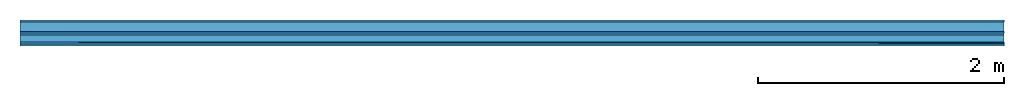
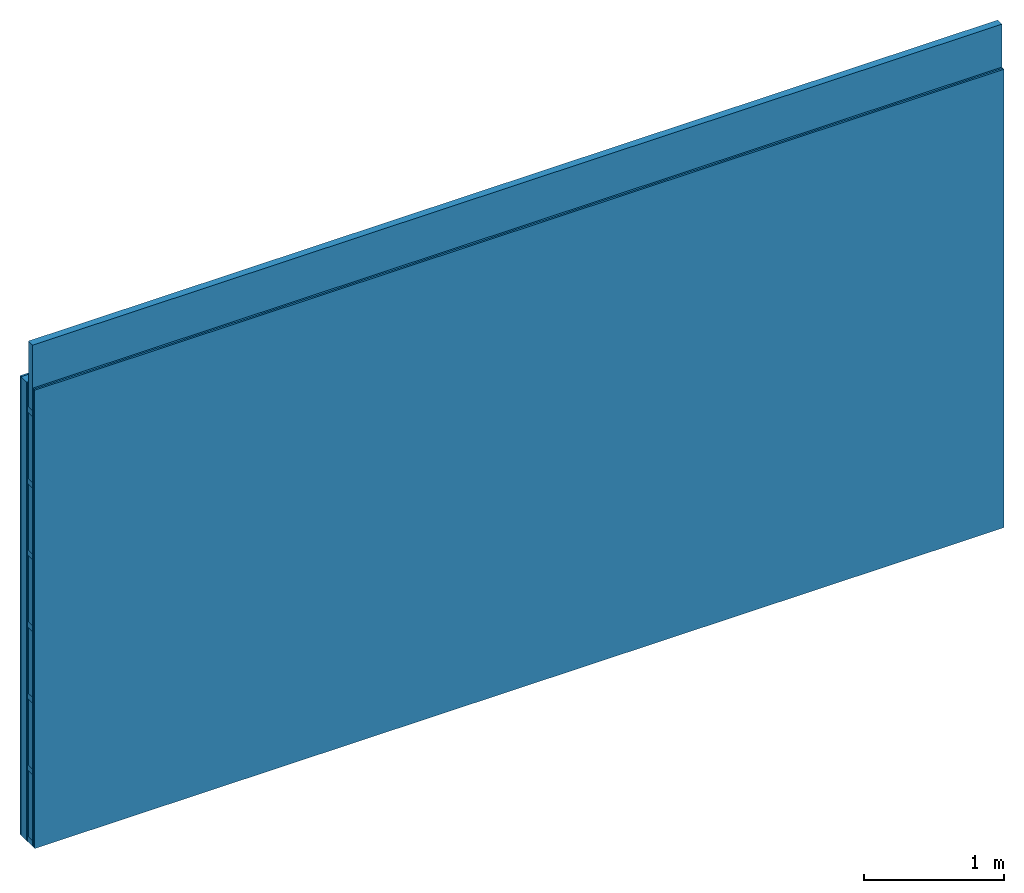
# One storey: 4 plates, 3 members, 1 element without a shape of its own.
"""IFC4 building model written with IfcOpenShell, lengths in metres."""

from ifc_helpers import new_model, si_unit, derived_unit, direction, frame, frame_2d, origin, origin_with_axes, place, context, project, spatial, rectangle, extrude, material, layer, layer_set, type_object, element, aggregate, save


model = new_model("IFC4")

# Units and contexts
plan_context = context("Plan", 3, precision=1e-05, world=origin(), true_north=direction((0.0, 1.0)))
model_context = context("Model", 3, precision=1e-05, world=origin(), true_north=direction((0.0, 1.0)))
ifc_project = project(units=[si_unit("LENGTHUNIT", "METRE"), derived_unit("SOUNDPRESSUREUNIT", [(si_unit("PRESSUREUNIT", "PASCAL", prefix="MICRO"), 0)]), si_unit("ENERGYUNIT", "JOULE", prefix="MEGA"), si_unit("MASSUNIT", "GRAM", prefix="KILO"), derived_unit("THERMALTRANSMITTANCEUNIT", [(si_unit("POWERUNIT", "WATT"), 1), (si_unit("AREAUNIT", "SQUARE_METRE"), -1), (si_unit("THERMODYNAMICTEMPERATUREUNIT", "KELVIN"), -1)]), derived_unit("AREADENSITYUNIT", [(si_unit("MASSUNIT", "GRAM", prefix="KILO"), 1), (si_unit("AREAUNIT", "SQUARE_METRE"), -1)]), derived_unit("USERDEFINED", [(si_unit("ENERGYUNIT", "JOULE", prefix="MEGA"), 1), (si_unit("AREAUNIT", "SQUARE_METRE"), -1)])], contexts=[plan_context, model_context])

# Site, building, storey
site = spatial("IfcSite", under=ifc_project)
building_placement = place(None, origin())
building = spatial("IfcBuilding", under=site, at=building_placement)
storey_placement = place(building_placement, origin())
storey = spatial("IfcBuildingStorey", under=building, at=storey_placement)

# Wall, members, plates
ifc_material_1 = material(Name="Glued joints")
ifc_layer_1 = layer(ifc_material_1, 0.0, Name="Surface")
ifc_material_2 = material(Category="03.007")
ifc_layer_2 = layer(ifc_material_2, 0.015, Name="1st layer")
ifc_material_3 = material(Name="of the art")
ifc_layer_3 = layer(ifc_material_3, 0.0, Name="Bond")
ifc_layer_4 = layer(None, 0.08, Name="Support")
ifc_material_4 = material(Name="Air")
ifc_layer_5 = layer(ifc_material_4, 0.01, Name="Coupling")
ifc_layer_6 = layer(None, 0.075, Name="Battens / profiles")
ifc_layer_7 = layer(ifc_material_2, 0.015, Name="Covering 1st layer")
ifc_layer_8 = layer(ifc_material_2, 0.015, Name="Covering 2nd layer")
ifc_layer_9 = layer(ifc_material_1, 0.0, Name="Surface")
ifc_layer_set = layer_set([ifc_layer_1, ifc_layer_2, ifc_layer_3, ifc_layer_4, ifc_layer_5, ifc_layer_6, ifc_layer_7, ifc_layer_8, ifc_layer_9])
wall_type = type_object("IfcWallType", Name="C0117", PredefinedType="NOTDEFINED", material=ifc_layer_set)
wall_placement = place(None, frame((0.0, 0.0, 0.0), z_axis=(0.0, -1.0, 0.0), x_axis=(1.0, 0.0, 0.0)))
wall = element("IfcWall", 1, at=wall_placement, inside=storey, type_object=wall_type, material=ifc_layer_set, Name="Wall #1")
ifc_material_5 = material()
member_1_placement = place(wall_placement, origin())
member_1 = element("IfcMember", 2, at=member_1_placement, material=ifc_material_5, Name="Support", context=plan_context, shape_type="SweptSolid", body=[
    extrude(rectangle(XDim=1.0, YDim=0.08, at=frame_2d((0.5, 0.04), x_axis=(1.0, 0.0))), frame((0.0, 4.0, 0.015), z_axis=(0.0, -1.0, 0.0), x_axis=(1.0, 0.0, 0.0)), (0.0, 0.0, 1.0), 4.0),
    extrude(rectangle(XDim=1.0, YDim=0.08, at=frame_2d((0.5, 0.04), x_axis=(1.0, 0.0))), frame((1.0, 4.0, 0.015), z_axis=(0.0, -1.0, 0.0), x_axis=(1.0, 0.0, 0.0)), (0.0, 0.0, 1.0), 4.0),
    extrude(rectangle(XDim=1.0, YDim=0.08, at=frame_2d((0.5, 0.04), x_axis=(1.0, 0.0))), frame((2.0, 4.0, 0.015), z_axis=(0.0, -1.0, 0.0), x_axis=(1.0, 0.0, 0.0)), (0.0, 0.0, 1.0), 4.0),
    extrude(rectangle(XDim=1.0, YDim=0.08, at=frame_2d((0.5, 0.04), x_axis=(1.0, 0.0))), frame((3.0, 4.0, 0.015), z_axis=(0.0, -1.0, 0.0), x_axis=(1.0, 0.0, 0.0)), (0.0, 0.0, 1.0), 4.0),
    extrude(rectangle(XDim=1.0, YDim=0.08, at=frame_2d((0.5, 0.04), x_axis=(1.0, 0.0))), frame((4.0, 4.0, 0.015), z_axis=(0.0, -1.0, 0.0), x_axis=(1.0, 0.0, 0.0)), (0.0, 0.0, 1.0), 4.0),
    extrude(rectangle(XDim=1.0, YDim=0.08, at=frame_2d((0.5, 0.04), x_axis=(1.0, 0.0))), frame((5.0, 4.0, 0.015), z_axis=(0.0, -1.0, 0.0), x_axis=(1.0, 0.0, 0.0)), (0.0, 0.0, 1.0), 4.0),
    extrude(rectangle(XDim=1.0, YDim=0.08, at=frame_2d((0.5, 0.04), x_axis=(1.0, 0.0))), frame((6.0, 4.0, 0.015), z_axis=(0.0, -1.0, 0.0), x_axis=(1.0, 0.0, 0.0)), (0.0, 0.0, 1.0), 4.0),
    extrude(rectangle(XDim=1.0, YDim=0.08, at=frame_2d((0.5, 0.04), x_axis=(1.0, 0.0))), frame((7.0, 4.0, 0.015), z_axis=(0.0, -1.0, 0.0), x_axis=(1.0, 0.0, 0.0)), (0.0, 0.0, 1.0), 4.0),
])
ifc_material_6 = material()
member_2_placement = place(wall_placement, origin())
member_2 = element("IfcMember", 3, at=member_2_placement, material=ifc_material_6, Name="Battens / profiles", context=plan_context, shape_type="SweptSolid", body=[
    extrude(rectangle(XDim=0.05, YDim=0.075, at=frame_2d((0.025, 0.0375), x_axis=(1.0, 0.0))), frame((0.0, 0.0, 0.105), z_axis=(1.0, 0.0, 0.0), x_axis=(0.0, 1.0, 0.0)), (0.0, 0.0, 1.0), 8.0),
    extrude(rectangle(XDim=0.05, YDim=0.075, at=frame_2d((0.025, 0.0375), x_axis=(1.0, 0.0))), frame((0.0, 0.625, 0.105), z_axis=(1.0, 0.0, 0.0), x_axis=(0.0, 1.0, 0.0)), (0.0, 0.0, 1.0), 8.0),
    extrude(rectangle(XDim=0.05, YDim=0.075, at=frame_2d((0.025, 0.0375), x_axis=(1.0, 0.0))), frame((0.0, 1.25, 0.105), z_axis=(1.0, 0.0, 0.0), x_axis=(0.0, 1.0, 0.0)), (0.0, 0.0, 1.0), 8.0),
    extrude(rectangle(XDim=0.05, YDim=0.075, at=frame_2d((0.025, 0.0375), x_axis=(1.0, 0.0))), frame((0.0, 1.875, 0.105), z_axis=(1.0, 0.0, 0.0), x_axis=(0.0, 1.0, 0.0)), (0.0, 0.0, 1.0), 8.0),
    extrude(rectangle(XDim=0.05, YDim=0.075, at=frame_2d((0.025, 0.0375), x_axis=(1.0, 0.0))), frame((0.0, 2.5, 0.105), z_axis=(1.0, 0.0, 0.0), x_axis=(0.0, 1.0, 0.0)), (0.0, 0.0, 1.0), 8.0),
    extrude(rectangle(XDim=0.05, YDim=0.075, at=frame_2d((0.025, 0.0375), x_axis=(1.0, 0.0))), frame((0.0, 3.125, 0.105), z_axis=(1.0, 0.0, 0.0), x_axis=(0.0, 1.0, 0.0)), (0.0, 0.0, 1.0), 8.0),
    extrude(rectangle(XDim=0.05, YDim=0.075, at=frame_2d((0.025, 0.0375), x_axis=(1.0, 0.0))), frame((0.0, 3.75, 0.105), z_axis=(1.0, 0.0, 0.0), x_axis=(0.0, 1.0, 0.0)), (0.0, 0.0, 1.0), 8.0),
])
ifc_material_7 = material()
member_3_placement = place(wall_placement, origin())
member_3 = element("IfcMember", 4, at=member_3_placement, material=ifc_material_7, Name="Cavity", context=plan_context, shape_type="SweptSolid", body=[
    extrude(rectangle(XDim=0.575, YDim=0.06, at=frame_2d((0.2875, 0.03), x_axis=(1.0, 0.0))), frame((0.0, 0.05, 0.12), z_axis=(1.0, 0.0, 0.0), x_axis=(0.0, 1.0, 0.0)), (0.0, 0.0, 1.0), 8.0),
    extrude(rectangle(XDim=0.575, YDim=0.06, at=frame_2d((0.2875, 0.03), x_axis=(1.0, 0.0))), frame((0.0, 0.675, 0.12), z_axis=(1.0, 0.0, 0.0), x_axis=(0.0, 1.0, 0.0)), (0.0, 0.0, 1.0), 8.0),
    extrude(rectangle(XDim=0.575, YDim=0.06, at=frame_2d((0.2875, 0.03), x_axis=(1.0, 0.0))), frame((0.0, 1.3, 0.12), z_axis=(1.0, 0.0, 0.0), x_axis=(0.0, 1.0, 0.0)), (0.0, 0.0, 1.0), 8.0),
    extrude(rectangle(XDim=0.575, YDim=0.06, at=frame_2d((0.2875, 0.03), x_axis=(1.0, 0.0))), frame((0.0, 1.925, 0.12), z_axis=(1.0, 0.0, 0.0), x_axis=(0.0, 1.0, 0.0)), (0.0, 0.0, 1.0), 8.0),
    extrude(rectangle(XDim=0.575, YDim=0.06, at=frame_2d((0.2875, 0.03), x_axis=(1.0, 0.0))), frame((0.0, 2.55, 0.12), z_axis=(1.0, 0.0, 0.0), x_axis=(0.0, 1.0, 0.0)), (0.0, 0.0, 1.0), 8.0),
    extrude(rectangle(XDim=0.575, YDim=0.06, at=frame_2d((0.2875, 0.03), x_axis=(1.0, 0.0))), frame((0.0, 3.175, 0.12), z_axis=(1.0, 0.0, 0.0), x_axis=(0.0, 1.0, 0.0)), (0.0, 0.0, 1.0), 8.0),
    extrude(rectangle(XDim=0.575, YDim=0.06, at=frame_2d((0.2875, 0.03), x_axis=(1.0, 0.0))), frame((0.0, 3.8, 0.12), z_axis=(1.0, 0.0, 0.0), x_axis=(0.0, 1.0, 0.0)), (0.0, 0.0, 1.0), 8.0),
])
plate_1_placement = place(wall_placement, origin())
plate_1 = element("IfcPlate", 5, at=plate_1_placement, material=ifc_material_2, Name="1st layer", context=plan_context, shape_type="SweptSolid", body=[
    extrude(rectangle(XDim=8.0, YDim=4.0, at=frame_2d((4.0, 2.0), x_axis=(1.0, 0.0))), origin_with_axes(), (0.0, 0.0, 1.0), 0.015),
])
plate_2_placement = place(wall_placement, origin())
plate_2 = element("IfcPlate", 6, at=plate_2_placement, material=ifc_material_4, Name="Coupling", context=plan_context, shape_type="SweptSolid", body=[
    extrude(rectangle(XDim=8.0, YDim=4.0, at=frame_2d((4.0, 2.0), x_axis=(1.0, 0.0))), frame((0.0, 0.0, 0.095), z_axis=(0.0, 0.0, 1.0), x_axis=(1.0, 0.0, 0.0)), (0.0, 0.0, 1.0), 0.01),
])
plate_3_placement = place(wall_placement, origin())
plate_3 = element("IfcPlate", 7, at=plate_3_placement, material=ifc_material_2, Name="Covering 1st layer", context=plan_context, shape_type="SweptSolid", body=[
    extrude(rectangle(XDim=8.0, YDim=4.0, at=frame_2d((4.0, 2.0), x_axis=(1.0, 0.0))), frame((0.0, 0.0, 0.18), z_axis=(0.0, 0.0, 1.0), x_axis=(1.0, 0.0, 0.0)), (0.0, 0.0, 1.0), 0.015),
])
plate_4_placement = place(wall_placement, origin())
plate_4 = element("IfcPlate", 8, at=plate_4_placement, material=ifc_material_2, Name="Covering 2nd layer", context=plan_context, shape_type="SweptSolid", body=[
    extrude(rectangle(XDim=8.0, YDim=4.0, at=frame_2d((4.0, 2.0), x_axis=(1.0, 0.0))), frame((0.0, 0.0, 0.195), z_axis=(0.0, 0.0, 1.0), x_axis=(1.0, 0.0, 0.0)), (0.0, 0.0, 1.0), 0.015),
])
aggregate(wall, [plate_1, member_1, plate_2, member_2, member_3, plate_3, plate_4])

save(model, "model.ifc")
